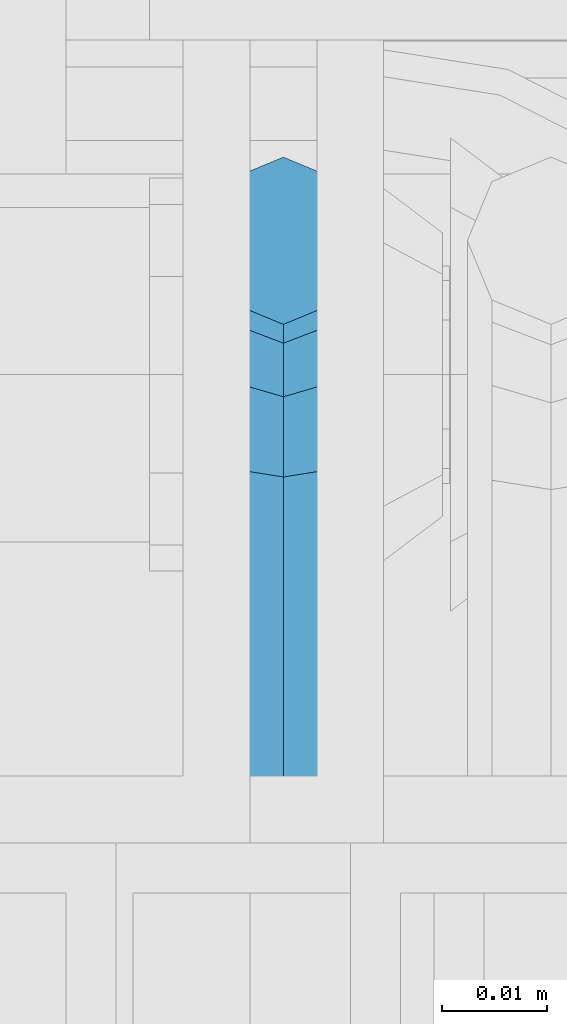
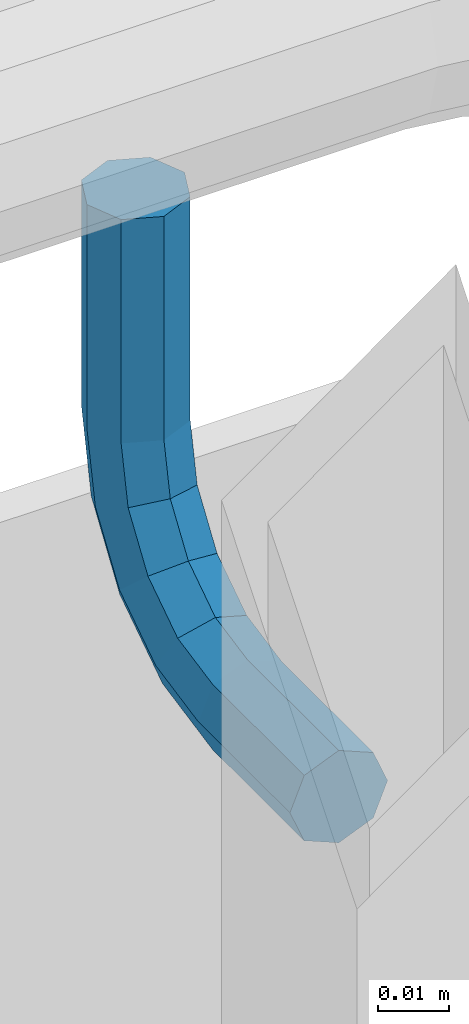
# One storey, part 1197 of 1876: 1 beam, 1 element without a shape of its own.
"""IFC2X3 building model written with IfcOpenShell, lengths in millimetres."""

from ifc_helpers import new_model, si_unit, frame, origin_with_axes, place, context, subcontext, project, spatial, faceted_brep, material, type_object, element, aggregate, save


model = new_model("IFC2X3")

# Units and contexts
model_context = context("Model", 3, precision=1e-05, world=origin_with_axes())
body_context = subcontext(model_context, "Body", "Model", "MODEL_VIEW")
ifc_project = project(units=[si_unit("LENGTHUNIT", "METRE", prefix="MILLI"), si_unit("AREAUNIT", "SQUARE_METRE"), si_unit("VOLUMEUNIT", "CUBIC_METRE"), si_unit("MASSUNIT", "GRAM", prefix="KILO"), si_unit("TIMEUNIT", "SECOND"), si_unit("PLANEANGLEUNIT", "RADIAN"), si_unit("SOLIDANGLEUNIT", "STERADIAN"), si_unit("THERMODYNAMICTEMPERATUREUNIT", "DEGREE_CELSIUS"), si_unit("LUMINOUSINTENSITYUNIT", "LUMEN")], contexts=[model_context])

# Site, building, storey
site_placement = place(None, origin_with_axes())
site = spatial("IfcSite", under=ifc_project, at=site_placement, CompositionType="ELEMENT")
building_placement = place(site_placement, origin_with_axes())
building = spatial("IfcBuilding", under=site, at=building_placement, Name="Undefined", CompositionType="ELEMENT")
storey_placement = place(building_placement, origin_with_axes())
storey = spatial("IfcBuildingStorey", under=building, at=storey_placement, Name="Undefined", CompositionType="ELEMENT", Elevation=0.0)

# Assembly, beam
assembly_placement = place(storey_placement, origin_with_axes())
assembly = element("IfcElementAssembly", 1, at=assembly_placement, inside=storey, Name="RAIL", AssemblyPlace="NOTDEFINED", PredefinedType="RIGID_FRAME")
ifc_material = material(Name="STEEL/A36")
beam_type = type_object("IfcBeamType", PredefinedType="NOTDEFINED")
beam_placement = place(assembly_placement, frame((6248.40006896043, -5715.00000114554, 3129.78360420196), z_axis=(1.0, 0.0, 0.0), x_axis=(0.0, 1.0, 0.0)))
beam = element("IfcBeam", 2, at=beam_placement, type_object=beam_type, material=ifc_material, Name="BRACKET", context=body_context, shape_type="Brep", body=[
    faceted_brep([(0.0, -7.9375, 0.0), (0.0, -5.61266007566822, -5.61266007566883), (25.7500019073486, -5.6126600756694, -5.61266007566974), (25.7500019073486, -7.93750000000102, -1.81898940354586e-12), (0.0, 0.0, -7.9375), (25.7500019073486, -6.82121026329696e-13, -7.93750000000091), (0.0, 5.61266007566822, -5.61266007566883), (25.7500019073486, 5.61266007566837, -5.61266007566837), (0.0, 7.9375, 0.0), (25.7500019073486, 7.93750000000102, 9.09494701772928e-13), (0.0, 5.61266007566822, 5.61266007566883), (25.7500019073486, 5.6126600756694, 5.61266007566928), (0.0, 0.0, 7.9375), (25.7500019073486, 6.82121026329696e-13, 7.93750000000045), (0.0, -5.61266007566822, 5.61266007566883), (25.7500019073486, -5.61266007566837, 5.61266007566746), (40.803811282025, -4.94311113920139, 1.49169682117645e-06), (39.9141340902152, -2.79523647837323, 5.6126606417356), (37.7662622873477, 2.39018638132939, 7.937498331401), (35.6183900453052, 7.57560705533251, 5.61265617240315), (34.728711793231, 9.7234764394143, -4.82889299746603e-06), (35.6183889850417, 7.57560177858613, -5.61266397893178), (37.7662607879083, 2.39017891888352, -7.93750166859718), (39.9141330299508, -2.79524175511915, -5.61265950959933), (51.9219035873093, 5.2280940203409, -5.61266511072881), (53.565814642534, 3.58418688334177, -4.46125068265246e-06), (47.9531531815637, 9.19684280310457, -7.93750642036139), (43.9844035873093, 13.1655940203409, -5.61266788133162), (42.3404944911981, 14.8095070346781, -8.37947573018027e-06), (43.9844055464218, 13.1655998976785, 5.6126522700024), (47.9531559521674, 9.19685111491481, 7.93749357963588), (51.9219055464218, 5.22809989767848, 5.61265504060611), (59.9452393627726, 17.2358645776962, -5.61267349341051), (62.0931126650794, 16.3461902438462, -1.33704661493539e-05), (54.7598170657875, 19.3837351967577, -7.93751353188054), (49.5743958290659, 21.5316086226071, -5.61267372168732), (47.4265250864628, 22.4212897326429, -1.36932976602111e-05), (49.5743983887696, 21.5316153987928, 5.61264642964761), (54.7598206857547, 19.3837447797314, 7.93748646811673), (59.9452419224763, 17.235871353882, 5.61264665792351), (62.7626602162454, 31.3999957002966, -5.61268338145874), (65.0875015258789, 31.3999996185225, -2.19204903260106e-05), (57.1499995667664, 31.399994077316, -7.93752192048851), (51.5373400649087, 31.3999957002989, -5.61268061085502), (49.2125015258789, 31.3999996185239, -1.99613778022467e-05), (51.5373428355124, 31.4000035367485, 5.61263954047809), (57.1500034849914, 31.4000051597295, 7.93747807950785), (62.7626629868482, 31.4000035367467, 5.61263676987437), (62.7626616015468, 69.8501202029533, -5.6126643254247), (65.0875015258789, 69.8501205444336, -4.24975678470219e-06), (57.1500015258789, 69.8501200615074, -7.93750424975678), (51.537341450211, 69.8501202029533, -5.6126643254247), (49.2125015258789, 69.8501205444336, -4.24975678470219e-06), (51.537341450211, 69.8501208859138, 5.61265582591113), (57.1500015258789, 69.8501210273598, 7.93749575024322), (62.7626616015468, 69.8501208859138, 5.61265582591113)], [[[0, 1, 2, 3]], [[1, 4, 5, 2]], [[4, 6, 7, 5]], [[6, 8, 9, 7]], [[8, 10, 11, 9]], [[10, 12, 13, 11]], [[12, 14, 15, 13]], [[14, 0, 3, 15]], [[14, 12, 10, 8, 6, 4, 1, 0]], [[15, 3, 16, 17]], [[13, 15, 17, 18]], [[11, 13, 18, 19]], [[9, 11, 19, 20]], [[7, 9, 20, 21]], [[5, 7, 21, 22]], [[2, 5, 22, 23]], [[3, 2, 23, 16]], [[23, 24, 25, 16]], [[22, 26, 24, 23]], [[21, 27, 26, 22]], [[20, 28, 27, 21]], [[19, 29, 28, 20]], [[18, 30, 29, 19]], [[17, 31, 30, 18]], [[16, 25, 31, 17]], [[24, 32, 33, 25]], [[26, 34, 32, 24]], [[27, 35, 34, 26]], [[28, 36, 35, 27]], [[29, 37, 36, 28]], [[30, 38, 37, 29]], [[31, 39, 38, 30]], [[25, 33, 39, 31]], [[32, 40, 41, 33]], [[34, 42, 40, 32]], [[35, 43, 42, 34]], [[36, 44, 43, 35]], [[37, 45, 44, 36]], [[38, 46, 45, 37]], [[39, 47, 46, 38]], [[33, 41, 47, 39]], [[41, 40, 48, 49]], [[40, 42, 50, 48]], [[42, 43, 51, 50]], [[43, 44, 52, 51]], [[44, 45, 53, 52]], [[45, 46, 54, 53]], [[46, 47, 55, 54]], [[47, 41, 49, 55]], [[50, 51, 52, 53, 54, 55, 49, 48]]]),
])
aggregate(assembly, [beam])

save(model, "model.ifc")
